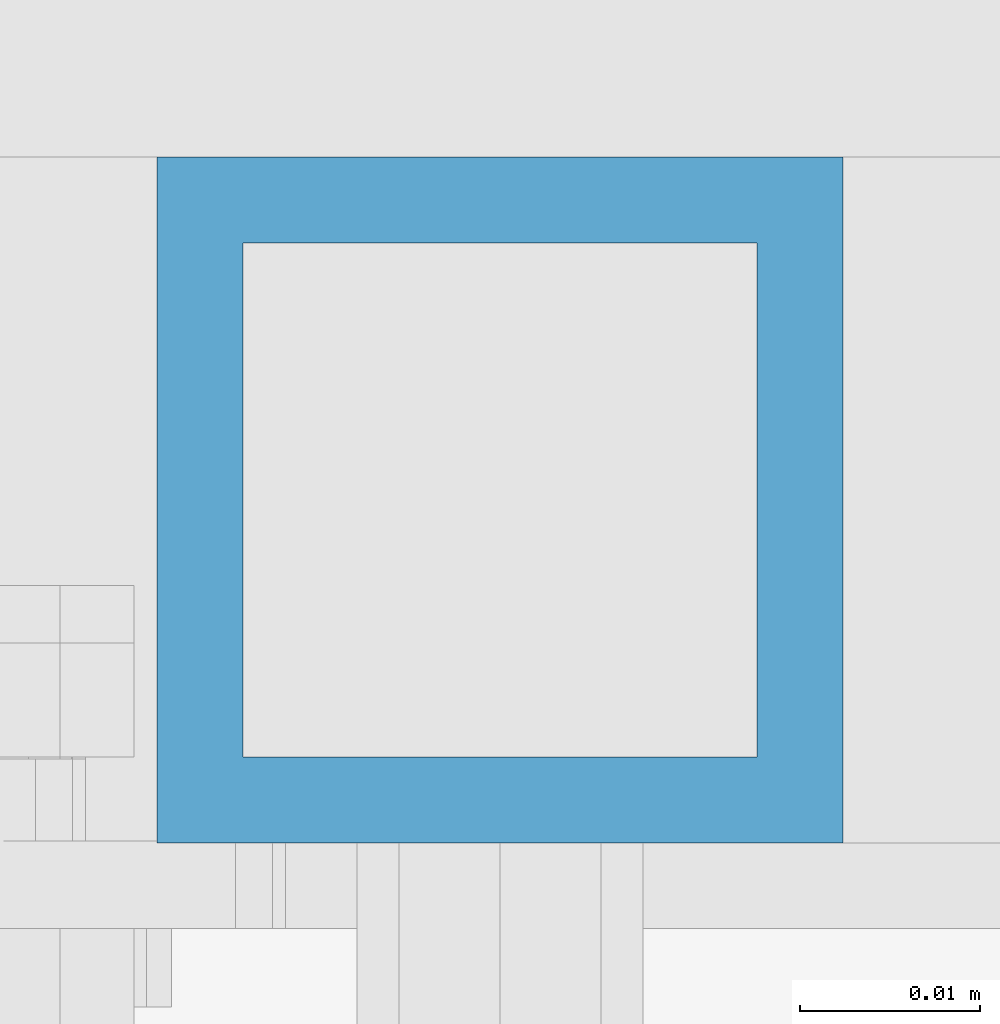
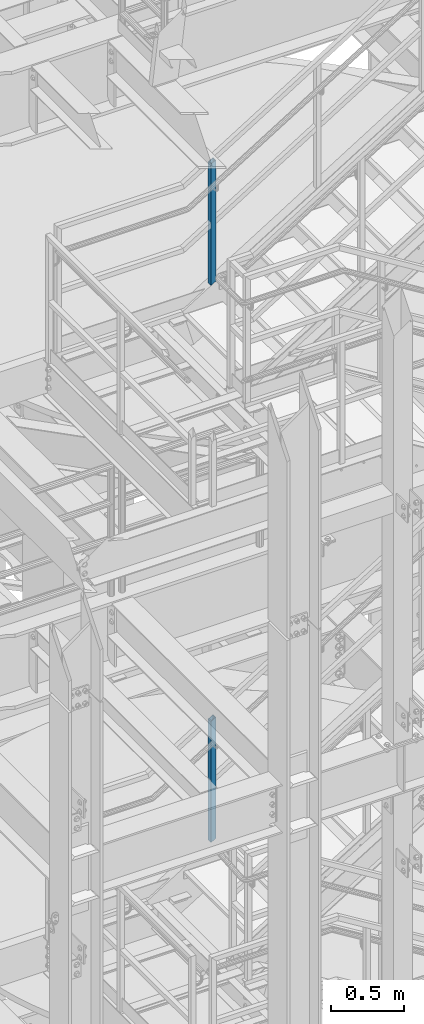
# One storey, part 610 of 1876: 2 columns, 2 elements without a shape of their own.
"""IFC2X3 building model written with IfcOpenShell, lengths in millimetres."""

from ifc_helpers import new_model, si_unit, frame, origin_with_axes, place, context, subcontext, project, spatial, faceted_brep, material, type_object, element, aggregate, save


model = new_model("IFC2X3")

# Units and contexts
model_context = context("Model", 3, precision=1e-05, world=origin_with_axes())
body_context = subcontext(model_context, "Body", "Model", "MODEL_VIEW")
ifc_project = project(units=[si_unit("LENGTHUNIT", "METRE", prefix="MILLI"), si_unit("AREAUNIT", "SQUARE_METRE"), si_unit("VOLUMEUNIT", "CUBIC_METRE"), si_unit("MASSUNIT", "GRAM", prefix="KILO"), si_unit("TIMEUNIT", "SECOND"), si_unit("PLANEANGLEUNIT", "RADIAN"), si_unit("SOLIDANGLEUNIT", "STERADIAN"), si_unit("THERMODYNAMICTEMPERATUREUNIT", "DEGREE_CELSIUS"), si_unit("LUMINOUSINTENSITYUNIT", "LUMEN")], contexts=[model_context])

# Site, building, storey
site_placement = place(None, origin_with_axes())
site = spatial("IfcSite", under=ifc_project, at=site_placement, CompositionType="ELEMENT")
building_placement = place(site_placement, origin_with_axes())
building = spatial("IfcBuilding", under=site, at=building_placement, Name="Undefined", CompositionType="ELEMENT")
storey_placement = place(building_placement, origin_with_axes())
storey = spatial("IfcBuildingStorey", under=building, at=storey_placement, Name="Undefined", CompositionType="ELEMENT", Elevation=0.0)

# Assembly, column
assembly_1_placement = place(storey_placement, origin_with_axes())
assembly_1 = element("IfcElementAssembly", 1, at=assembly_1_placement, inside=storey, Name="RAIL", AssemblyPlace="NOTDEFINED", PredefinedType="RIGID_FRAME")
ifc_material = material()
column_type = type_object("IfcColumnType", Name="HSS1-1/2X1-1/2X3/16", PredefinedType="NOTDEFINED")
column_1_placement = place(assembly_1_placement, frame((2419.35000034996, -4781.55000114554, 11087.2492458267), z_axis=(-1.0, 0.0, 0.0), x_axis=(0.0, 0.0, 1.0)))
column_1 = element("IfcColumn", 2, at=column_1_placement, type_object=column_type, material=ifc_material, Name="POST", ObjectType="HSS1-1/2X1-1/2X3/16", context=body_context, shape_type="Brep", body=[
    faceted_brep([(1026.33175871902, -19.0500000000002, -19.0499992350001), (1026.33175871902, 19.0499992349996, -19.0499992350001), (1002.89450115962, 19.0499992349996, 19.0499992349996), (1002.89450115962, -19.0499992349996, 19.0499992349996), (1023.40208377724, -14.2874994260001, -14.2874994260001), (1005.82416013402, -14.2874994260001, 14.2874994260001), (1005.82416013402, 14.2874994260001, 14.2874994260001), (1023.40208377724, 14.2874994260001, -14.2874994260001), (-11.7186358969739, 19.0499992349996, 19.0499992349996), (-11.7186358969739, -19.0499992349996, 19.0499992349996), (11.7186358969793, -19.0499992349996, -19.0499992349996), (11.7186358969793, 19.0499992349996, -19.0499992349996), (-8.78902482466219, 14.2874994260001, 14.2874994260001), (-8.78902482466219, -14.2874994260001, 14.2874994260001), (8.78902482575359, -14.2874994260001, -14.2874994260001), (8.78902482575359, 14.2874994260001, -14.2874994260001)], [[[0, 1, 2, 3], [4, 5, 6, 7]], [[8, 9, 3, 2]], [[9, 10, 0, 3]], [[10, 11, 1, 0]], [[11, 8, 2, 1]], [[10, 9, 8, 11], [12, 13, 14, 15]], [[15, 14, 4, 7]], [[12, 15, 7, 6]], [[13, 12, 6, 5]], [[14, 13, 5, 4]]]),
])
aggregate(assembly_1, [column_1])

assembly_2_placement = place(storey_placement, origin_with_axes())
assembly_2 = element("IfcElementAssembly", 3, at=assembly_2_placement, inside=storey, Name="RAIL", AssemblyPlace="NOTDEFINED", PredefinedType="RIGID_FRAME")
column_2_placement = place(assembly_2_placement, frame((2419.34999989024, -4781.55000114554, 15744.9508195396), z_axis=(-1.0, 0.0, 0.0), x_axis=(0.0, 0.0, 1.0)))
column_2 = element("IfcColumn", 4, at=column_2_placement, type_object=column_type, material=ifc_material, Name="POST", ObjectType="HSS1-1/2X1-1/2X3/16", context=body_context, shape_type="Brep", body=[
    faceted_brep([(1026.31311450052, -19.0500000000002, -19.0499992349996), (1026.31311450052, 19.0499992349996, -19.0499992349996), (1002.71048974224, 19.0499992349996, 19.0499992349996), (1002.71048974224, -19.0499992349996, 19.0499992349996), (1023.36278640575, -14.2874994260001, -14.2874994260001), (1005.66081783739, -14.2874994260001, 14.2874994260001), (1005.66081783739, 14.2874994260001, 14.2874994260001), (1023.36278640575, 14.2874994260001, -14.2874994260001), (-11.8013123776254, 19.0499992349996, 19.0499992349996), (-11.8013123776254, -19.0499992349996, 19.0499992349996), (11.8013123805795, -19.0499992349996, -19.0499992349996), (11.8013123805795, 19.0499992349996, -19.0499992349996), (-8.85098428269339, 14.2874994260001, 14.2874994260001), (-8.85098428269339, -14.2874994260001, 14.2874994260001), (8.85098428565107, -14.2874994260001, -14.2874994260001), (8.85098428565107, 14.2874994260001, -14.2874994260001)], [[[0, 1, 2, 3], [4, 5, 6, 7]], [[8, 9, 3, 2]], [[9, 10, 0, 3]], [[10, 11, 1, 0]], [[11, 8, 2, 1]], [[10, 9, 8, 11], [12, 13, 14, 15]], [[15, 14, 4, 7]], [[12, 15, 7, 6]], [[13, 12, 6, 5]], [[14, 13, 5, 4]]]),
])
aggregate(assembly_2, [column_2])

save(model, "model.ifc")
